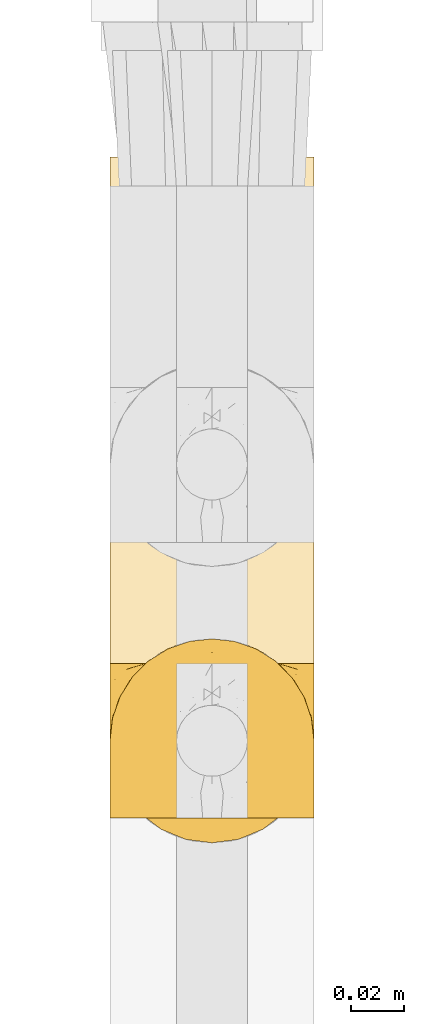
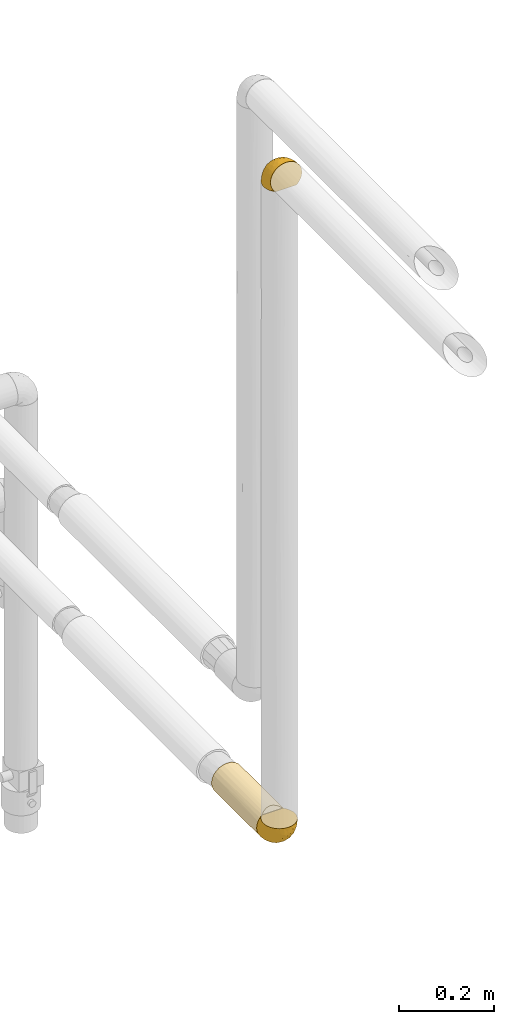
# One storey, part 60 of 827: 3 coverings.
"""IFC2X3 building model written with IfcOpenShell, lengths in millimetres."""

import ifcopenshell
import ifcopenshell.guid

model = None  # the IFC model being written
_history = None  # IfcOwnerHistory: only IFC2X3 demands one
_inside = {}  # id of a spatial element -> (the spatial element, [elements in it])
_under = {}  # id of a project, library or spatial element -> (it, [spatial elements below it])
_declared = {}  # id of a project -> (the project, [libraries it declares])
_typed = {}  # id of a type object -> (the type object, [elements of that type])
_made_of = {}  # id of a material, layer set ... -> (it, [elements and type objects made of it])


def new_model(schema):
    """Start an empty IFC model of exactly this schema.

    Asked for "IFC4X3", IfcOpenShell would pick the latest addendum, in which some entities
    have other attributes; the version numbers below select the first issue.
    IFC2X3 requires an IfcOwnerHistory on every rooted entity: one is made here for all.
    """
    global model, _history
    if schema == "IFC4X3":
        model = ifcopenshell.file(schema_version=(4, 3, 0, 0))
    else:
        model = ifcopenshell.file(schema=schema)
    _inside.clear()
    _under.clear()
    _declared.clear()
    _typed.clear()
    _made_of.clear()
    _history = None
    if model.schema == "IFC2X3":
        org = make("IfcOrganization", Name="unknown")
        user = make(
            "IfcPersonAndOrganization",
            ThePerson=make("IfcPerson", FamilyName="unknown"),
            TheOrganization=org,
        )
        app = make(
            "IfcApplication",
            ApplicationDeveloper=org,
            Version="unknown",
            ApplicationFullName="unknown",
            ApplicationIdentifier="unknown",
        )
        _history = make(
            "IfcOwnerHistory",
            OwningUser=user,
            OwningApplication=app,
            ChangeAction="ADDED",
            CreationDate=0,
        )
    return model


def make(cls, **values):
    """One entity of the class cls with the attributes given. An attribute that is None is left unset."""
    return model.create_entity(
        cls, **{name: value for name, value in values.items() if value is not None}
    )


def entity(cls, *values):
    """Any entity or typed value of the class cls, its attributes in the order of the schema. None: left unset."""
    e = model.create_entity(cls)
    for i, value in enumerate(values):
        if value is not None:
            e[i] = value
    return e


def rooted(cls, **values):
    """An entity with a GlobalId (a new one), such as an element, a storey or a relation."""
    return make(cls, GlobalId=ifcopenshell.guid.new(), OwnerHistory=_history, **values)


def si_unit(unit_type, name, prefix=None):
    """IfcSIUnit, for example si_unit("LENGTHUNIT", "METRE", prefix="MILLI")."""
    return make("IfcSIUnit", UnitType=unit_type, Prefix=prefix, Name=name)


def converted_unit(unit_type, name, factor, base, dimensions=None, offset=None):
    """IfcConversionBasedUnit, such as the inch: factor (a typed value) times the base unit."""
    return make(
        "IfcConversionBasedUnit"
        if offset is None
        else "IfcConversionBasedUnitWithOffset",
        ConversionOffset=offset,
        Dimensions=None
        if dimensions is None
        else entity("IfcDimensionalExponents", *dimensions),
        UnitType=unit_type,
        Name=name,
        ConversionFactor=make(
            "IfcMeasureWithUnit", ValueComponent=factor, UnitComponent=base
        ),
    )


def derived_unit(unit_type, elements):
    """IfcDerivedUnit: a product of units, each with its exponent."""
    return make(
        "IfcDerivedUnit",
        Elements=[
            make("IfcDerivedUnitElement", Unit=unit, Exponent=power)
            for unit, power in elements
        ],
        UnitType=unit_type,
    )


def assignment(units):
    """IfcUnitAssignment: the units of a project."""
    return None if units is None else make("IfcUnitAssignment", Units=units)


def point(xyz):
    """IfcCartesianPoint."""
    return None if xyz is None else make("IfcCartesianPoint", Coordinates=xyz)


def direction(xyz):
    """IfcDirection."""
    return None if xyz is None else make("IfcDirection", DirectionRatios=xyz)


def frame(location, z_axis=None, x_axis=None):
    """IfcAxis2Placement3D, a coordinate frame: its origin and axes. An axis left out is left unset."""
    return make(
        "IfcAxis2Placement3D",
        Location=point(location),
        Axis=direction(z_axis),
        RefDirection=direction(x_axis),
    )


def origin():
    """The frame at (0, 0, 0) with its axes left unset."""
    return frame((0.0, 0.0, 0.0))


def place(relative_to, where):
    """IfcLocalPlacement: puts the frame where relative to a parent placement (None: the world)."""
    return make(
        "IfcLocalPlacement", PlacementRelTo=relative_to, RelativePlacement=where
    )


def context(
    kind, dimensions, precision=None, world=None, true_north=None, identifier=None
):
    """IfcGeometricRepresentationContext, for example the 3D "Model" context."""
    return make(
        "IfcGeometricRepresentationContext",
        ContextIdentifier=identifier,
        ContextType=kind,
        CoordinateSpaceDimension=dimensions,
        Precision=precision,
        WorldCoordinateSystem=world,
        TrueNorth=true_north,
    )


def subcontext(parent, identifier, kind, view, scale=None):
    """IfcGeometricRepresentationSubContext, for example "Body" below "Model"."""
    return make(
        "IfcGeometricRepresentationSubContext",
        ContextIdentifier=identifier,
        ContextType=kind,
        ParentContext=parent,
        TargetScale=scale,
        TargetView=view,
    )


def project(units=None, contexts=None):
    """IfcProject with its units and contexts."""
    return rooted(
        "IfcProject",
        Name="project",
        RepresentationContexts=contexts,
        UnitsInContext=assignment(units),
    )


def spatial(cls, under=None, at=None, **own):
    """A site, building, storey or space (cls), placed at a placement, below another one or the project."""
    s = rooted(cls, ObjectPlacement=at, **own)
    if under is not None:
        _under.setdefault(under.id(), (under, []))[1].append(s)
    return s


def faces_of(points, faces, orient=None, outer=None):
    """IfcFace entities. A face is a list of loops; a loop is a list of indices into points, from 0.

    orient and outer hold one flag for each loop. By default every Orientation is true, the
    first loop of a face is its IfcFaceOuterBound and the others are IfcFaceBound.
    """
    made = []
    for i, loops in enumerate(faces):
        bounds = []
        for j, loop in enumerate(loops):
            is_outer = j == 0 if outer is None else outer[i][j]
            bounds.append(
                make(
                    "IfcFaceOuterBound" if is_outer else "IfcFaceBound",
                    Bound=make("IfcPolyLoop", Polygon=[points[k] for k in loop]),
                    Orientation=True if orient is None else orient[i][j],
                )
            )
        made.append(make("IfcFace", Bounds=bounds))
    return made


def faceted_brep(points, faces, orient=None, outer=None, voids=None):
    """IfcFacetedBrep: a solid bounded by flat faces; with voids (closed shells), ...WithVoids."""
    shared = [point(p) for p in points]
    hull = make("IfcClosedShell", CfsFaces=faces_of(shared, faces, orient, outer))
    if voids is None:
        return make("IfcFacetedBrep", Outer=hull)
    return make(
        "IfcFacetedBrepWithVoids",
        Outer=hull,
        Voids=[
            make(cls, CfsFaces=faces_of(shared, fs, o, b)) for cls, fs, o, b in voids
        ],
    )


def shape(context_of_items, identifier, shape_type, items):
    """IfcShapeRepresentation: the items that make up one representation, for example the "Body"."""
    return make(
        "IfcShapeRepresentation",
        ContextOfItems=context_of_items,
        RepresentationIdentifier=identifier,
        RepresentationType=shape_type,
        Items=items,
    )


def made_of(thing, what):
    """Note that an element or type object is made of a material, layer set ...; save() writes the relation."""
    if what is not None:
        _made_of.setdefault(what.id(), (what, []))[1].append(thing)
    return thing


def element(
    cls,
    number,
    at=None,
    inside=None,
    cuts=None,
    type_object=None,
    material=None,
    context=None,
    identifier="Body",
    shape_type=None,
    held_by="IfcProductDefinitionShape",
    body=None,
    shapes=None,
    **own,
):
    """One element of the class cls, such as IfcWall. Its Tag is "e" and its number.

    at: its placement. inside: the storey or other place that contains it. cuts: it is an
    opening in that element (IfcRelVoidsElement). A single representation is given by context,
    identifier, shape_type and body (its items); several are given by shapes. held_by: the class
    of the entity that holds the representations. save() writes the other relations.
    """
    e = rooted(cls, Tag="e%d" % number, ObjectPlacement=at, **own)
    if body is not None:
        shapes = [shape(context, identifier, shape_type, body)]
    if shapes is not None:
        e.Representation = make(held_by, Representations=shapes)
    if inside is not None:
        _inside.setdefault(inside.id(), (inside, []))[1].append(e)
    if cuts is not None:
        rooted(
            "IfcRelVoidsElement", RelatingBuildingElement=cuts, RelatedOpeningElement=e
        )
    if type_object is not None:
        _typed.setdefault(type_object.id(), (type_object, []))[1].append(e)
    return made_of(e, material)


def aggregate(whole, parts):
    """IfcRelAggregates: a whole, such as a stair, and the parts it consists of."""
    return rooted("IfcRelAggregates", RelatingObject=whole, RelatedObjects=parts)


def save(model, path):
    """Write the relations noted so far, then the file.

    IfcRelAggregates (storeys below a building ...), IfcRelContainedInSpatialStructure (elements
    in a storey), IfcRelDefinesByType, IfcRelAssociatesMaterial and IfcRelDeclares: one each for
    every whole, place, type object, material and project.
    """
    for whole, parts in _under.values():
        aggregate(whole, parts)
    for where, things in _inside.values():
        rooted(
            "IfcRelContainedInSpatialStructure",
            RelatedElements=things,
            RelatingStructure=where,
        )
    for kind, things in _typed.values():
        rooted("IfcRelDefinesByType", RelatedObjects=things, RelatingType=kind)
    for what, things in _made_of.values():
        rooted("IfcRelAssociatesMaterial", RelatedObjects=things, RelatingMaterial=what)
    for by, libraries in _declared.values():
        rooted("IfcRelDeclares", RelatingContext=by, RelatedDefinitions=libraries)
    model.write(path)


model = new_model("IFC2X3")

# Units and contexts
model_context = context("Model", 3, precision=0.01, world=origin(), true_north=direction((6.12303176911189e-17, 1.0)))
body_context = subcontext(model_context, "Body", "Model", "MODEL_VIEW")
ifc_project = project(units=[si_unit("LENGTHUNIT", "METRE", prefix="MILLI"), si_unit("AREAUNIT", "SQUARE_METRE"), si_unit("VOLUMEUNIT", "CUBIC_METRE"), converted_unit("PLANEANGLEUNIT", "DEGREE", entity("IfcRatioMeasure", 0.0174532925199433), si_unit("PLANEANGLEUNIT", "RADIAN"), dimensions=[0, 0, 0, 0, 0, 0, 0]), si_unit("MASSUNIT", "GRAM", prefix="KILO"), derived_unit("MASSDENSITYUNIT", [(si_unit("MASSUNIT", "GRAM", prefix="KILO"), 1), (si_unit("LENGTHUNIT", "METRE"), -3)]), derived_unit("MOMENTOFINERTIAUNIT", [(si_unit("LENGTHUNIT", "METRE"), 4)]), si_unit("TIMEUNIT", "SECOND"), si_unit("FREQUENCYUNIT", "HERTZ"), si_unit("THERMODYNAMICTEMPERATUREUNIT", "DEGREE_CELSIUS"), derived_unit("THERMALTRANSMITTANCEUNIT", [(si_unit("MASSUNIT", "GRAM", prefix="KILO"), 1), (si_unit("THERMODYNAMICTEMPERATUREUNIT", "KELVIN"), -1), (si_unit("TIMEUNIT", "SECOND"), -3)]), derived_unit("VOLUMETRICFLOWRATEUNIT", [(si_unit("LENGTHUNIT", "METRE"), 3), (si_unit("TIMEUNIT", "SECOND"), -1)]), derived_unit("MASSFLOWRATEUNIT", [(si_unit("MASSUNIT", "GRAM", prefix="KILO"), 1), (si_unit("TIMEUNIT", "SECOND"), -1)]), derived_unit("ROTATIONALFREQUENCYUNIT", [(si_unit("TIMEUNIT", "SECOND"), -1)]), si_unit("ELECTRICCURRENTUNIT", "AMPERE"), si_unit("ELECTRICVOLTAGEUNIT", "VOLT"), si_unit("POWERUNIT", "WATT"), si_unit("FORCEUNIT", "NEWTON", prefix="KILO"), si_unit("ILLUMINANCEUNIT", "LUX"), si_unit("LUMINOUSFLUXUNIT", "LUMEN"), si_unit("LUMINOUSINTENSITYUNIT", "CANDELA"), derived_unit("USERDEFINED", [(si_unit("MASSUNIT", "GRAM", prefix="KILO"), -1), (si_unit("LENGTHUNIT", "METRE"), -2), (si_unit("TIMEUNIT", "SECOND"), 3), (si_unit("LUMINOUSFLUXUNIT", "LUMEN"), 1)]), derived_unit("LINEARVELOCITYUNIT", [(si_unit("LENGTHUNIT", "METRE"), 1), (si_unit("TIMEUNIT", "SECOND"), -1)]), si_unit("PRESSUREUNIT", "PASCAL"), derived_unit("USERDEFINED", [(si_unit("LENGTHUNIT", "METRE"), -2), (si_unit("MASSUNIT", "GRAM", prefix="KILO"), 1), (si_unit("TIMEUNIT", "SECOND"), -2)]), derived_unit("LINEARFORCEUNIT", [(si_unit("MASSUNIT", "GRAM", prefix="KILO"), 1), (si_unit("LENGTHUNIT", "METRE"), 1), (si_unit("TIMEUNIT", "SECOND"), -2), (si_unit("LENGTHUNIT", "METRE"), -1)]), derived_unit("PLANARFORCEUNIT", [(si_unit("MASSUNIT", "GRAM", prefix="KILO"), 1), (si_unit("LENGTHUNIT", "METRE"), 1), (si_unit("TIMEUNIT", "SECOND"), -2), (si_unit("LENGTHUNIT", "METRE"), -2)])], contexts=[model_context])

# Site, building, storey
site_placement = place(None, origin())
site = spatial("IfcSite", under=ifc_project, at=site_placement, CompositionType="ELEMENT")
building_placement = place(site_placement, origin())
building = spatial("IfcBuilding", under=site, at=building_placement, CompositionType="ELEMENT")
storey_placement = place(building_placement, frame((0.0, 0.0, 28200.0)))
storey = spatial("IfcBuildingStorey", under=building, at=storey_placement, Name="08", CompositionType="ELEMENT", Elevation=28200.0)

# Coverings
covering_1_placement = place(storey_placement, frame((13238.75, 11029.69, 2669.3)))
element("IfcCovering", 1, at=covering_1_placement, inside=storey, Name=":ADSK_", ObjectType=":ADSK_", PredefinedType="INSULATION", context=body_context, shape_type="Brep", body=[
    faceted_brep([(5.41, 47.38, 1.6), (9.99, 54.67, 1.6), (16.08, 60.76, 1.6), (23.37, 65.34, 1.6), (31.49, 68.18, 1.6), (40.05, 69.15, 1.6), (48.61, 68.18, 1.6), (56.73, 65.33, 1.6), (64.02, 60.75, 1.6), (70.11, 54.66, 1.6), (74.69, 47.37, 1.6), (77.53, 39.25, 1.6), (78.5, 30.7, 1.6), (77.63, 22.59, 1.6), (75.08, 14.86, 1.6), (70.97, 7.84, 1.6), (65.47, 1.85, 1.6), (63.27, 1.85, 1.6), (61.53, 1.85, 1.6), (59.57, 1.85, 1.6), (57.6, 1.85, 1.6), (55.63, 1.85, 1.6), (53.67, 1.85, 1.6), (51.7, 1.85, 1.6), (49.73, 1.85, 1.6), (47.54, 1.85, 1.6), (45.34, 1.85, 1.6), (43.15, 1.85, 1.6), (40.96, 1.85, 1.6), (38.76, 1.85, 1.6), (36.57, 1.85, 1.6), (34.37, 1.85, 1.6), (32.18, 1.85, 1.6), (29.98, 1.85, 1.6), (27.79, 1.85, 1.6), (25.6, 1.85, 1.6), (23.4, 1.85, 1.6), (21.21, 1.85, 1.6), (19.01, 1.85, 1.6), (16.82, 1.85, 1.6), (14.62, 1.85, 1.6), (9.12, 7.85, 1.6), (5.0, 14.88, 1.6), (2.46, 22.61, 1.6), (1.6, 30.7, 1.6), (2.56, 39.26, 1.6), (65.47, 1.6, 1.85), (70.97, 1.6, 7.85), (75.09, 1.6, 14.87), (77.63, 1.6, 22.6), (78.5, 1.6, 30.7), (77.19, 1.6, 40.65), (73.34, 1.6, 49.92), (67.23, 1.6, 57.88), (59.27, 1.6, 63.99), (50.0, 1.6, 67.84), (40.05, 1.6, 69.15), (30.09, 1.6, 67.84), (20.82, 1.6, 63.99), (12.86, 1.6, 57.88), (6.75, 1.6, 49.92), (2.91, 1.6, 40.65), (1.6, 1.6, 30.7), (2.46, 1.6, 22.6), (5.0, 1.6, 14.87), (9.12, 1.6, 7.85), (14.62, 1.6, 1.85), (16.82, 1.6, 1.85), (17.8, 1.6, 1.85), (19.39, 1.6, 1.85), (20.98, 1.6, 1.85), (22.57, 1.6, 1.85), (24.16, 1.6, 1.85), (25.75, 1.6, 1.85), (27.33, 1.6, 1.85), (28.92, 1.6, 1.85), (30.51, 1.6, 1.85), (32.1, 1.6, 1.85), (33.69, 1.6, 1.85), (35.28, 1.6, 1.85), (36.87, 1.6, 1.85), (38.46, 1.6, 1.85), (40.05, 1.6, 1.85), (41.63, 1.6, 1.85), (43.22, 1.6, 1.85), (44.81, 1.6, 1.85), (46.4, 1.6, 1.85), (47.99, 1.6, 1.85), (49.58, 1.6, 1.85), (51.17, 1.6, 1.85), (52.76, 1.6, 1.85), (54.72, 1.6, 1.85), (56.69, 1.6, 1.85), (58.88, 1.6, 1.85), (61.08, 1.6, 1.85), (63.27, 1.6, 1.85), (37.77, 1.78, 1.77), (36.07, 1.77, 1.78), (32.96, 1.78, 1.77), (31.36, 1.77, 1.77), (56.52, 1.79, 1.76), (54.96, 1.78, 1.77), (18.75, 1.76, 1.79), (58.07, 1.77, 1.78), (50.37, 1.77, 1.78), (23.36, 1.76, 1.78), (24.95, 1.77, 1.78), (42.43, 1.77, 1.78), (15.97, 1.8, 1.74), (51.96, 1.76, 1.78), (53.47, 1.77, 1.78), (48.63, 1.78, 1.77), (63.93, 1.77, 1.78), (40.93, 1.77, 1.78), (29.72, 1.76, 1.78), (62.4, 1.77, 1.77), (60.92, 1.78, 1.77), (17.31, 1.77, 1.77), (21.74, 1.77, 1.78), (34.56, 1.77, 1.78), (20.18, 1.78, 1.77), (14.62, 1.77, 1.77), (14.62, 1.8, 1.72), (14.62, 1.82, 1.66), (65.47, 1.77, 1.77), (65.47, 1.72, 1.8), (65.47, 1.66, 1.82), (59.5, 1.76, 1.79), (47.1, 1.77, 1.78), (45.61, 1.76, 1.79), (28.18, 1.77, 1.78), (14.62, 1.66, 1.82), (14.62, 1.72, 1.8), (26.61, 1.78, 1.76), (65.47, 1.82, 1.66), (65.47, 1.8, 1.72), (39.32, 1.77, 1.78), (44.12, 1.78, 1.77), (72.26, 3.72, 9.41), (76.57, 7.41, 17.65), (71.77, 6.13, 7.41), (78.5, 21.47, 21.47), (77.9, 19.34, 15.21), (78.5, 26.8, 16.15), (78.5, 8.87, 28.75), (75.52, 9.2, 13.67), (76.13, 12.79, 12.79), (77.81, 14.62, 19.18), (78.5, 7.34, 29.16), (72.4, 5.33, 9.04), (76.56, 17.64, 7.41), (71.77, 7.7, 5.74), (72.25, 9.41, 3.72), (78.5, 28.75, 8.87), (78.5, 16.15, 26.8), (75.75, 14.14, 9.53), (78.5, 29.16, 7.34), (50.46, 57.02, 37.63), (52.75, 64.92, 17.92), (40.05, 64.0, 27.45), (77.7, 11.92, 37.01), (77.66, 19.16, 34.22), (71.02, 28.65, 45.87), (63.45, 24.62, 56.57), (70.55, 15.19, 52.31), (75.57, 18.36, 42.07), (75.57, 9.2, 44.74), (72.61, 46.98, 21.49), (72.61, 50.24, 11.02), (67.24, 56.1, 15.64), (77.74, 28.97, 26.02), (57.43, 54.46, 36.59), (47.19, 21.34, 65.49), (54.76, 18.4, 63.99), (40.05, 66.44, 15.2), (63.45, 12.07, 60.27), (60.1, 45.49, 45.25), (63.72, 50.57, 35.21), (76.83, 36.04, 22.52), (76.34, 42.07, 12.03), (60.51, 62.12, 13.32), (72.59, 37.37, 35.9), (76.05, 29.39, 33.87), (66.15, 53.59, 25.73), (60.51, 58.06, 26.34), (51.88, 49.27, 46.78), (55.34, 29.63, 59.54), (48.67, 33.21, 60.18), (53.89, 40.1, 53.93), (46.73, 44.08, 53.36), (40.05, 49.36, 49.36), (40.05, 56.68, 38.4), (40.05, 15.2, 66.44), (63.95, 35.57, 50.09), (67.24, 41.7, 41.08), (69.62, 46.4, 31.14), (73.6, 41.41, 28.19), (40.05, 27.45, 64.0), (40.05, 38.4, 56.68), (4.52, 12.99, 43.9), (32.72, 21.33, 65.46), (27.18, 42.89, 52.22), (29.63, 57.04, 37.61), (12.86, 56.11, 15.64), (19.59, 62.13, 13.31), (9.54, 21.89, 50.02), (16.64, 16.62, 59.28), (17.48, 32.9, 53.05), (7.49, 46.99, 21.48), (7.49, 50.25, 11.01), (3.75, 42.08, 12.03), (20.75, 49.91, 41.02), (2.33, 15.6, 35.39), (1.6, 16.15, 26.8), (1.6, 8.87, 28.75), (1.6, 29.16, 7.34), (26.94, 13.16, 65.81), (9.54, 10.83, 53.28), (31.21, 33.8, 59.8), (25.33, 25.02, 61.82), (27.35, 64.92, 17.91), (8.17, 32.83, 41.4), (4.3, 20.56, 40.48), (19.59, 58.07, 26.34), (2.23, 21.46, 31.68), (2.45, 28.1, 27.68), (1.6, 26.8, 16.15), (1.6, 21.47, 21.47), (12.86, 51.29, 28.05), (3.27, 36.04, 22.54), (1.6, 28.75, 8.87), (2.29, 8.45, 37.3), (12.86, 41.73, 41.07), (6.89, 39.27, 32.24), (12.43, 33.56, 47.4), (4.1, 27.29, 35.77), (3.53, 7.41, 17.65), (6.88, 3.51, 11.06), (8.16, 4.68, 8.55), (9.02, 5.52, 6.63), (5.0, 8.75, 12.77), (3.96, 12.79, 12.79), (3.52, 17.65, 7.41), (2.4, 13.9, 18.97), (7.83, 9.42, 3.72), (8.32, 7.68, 5.76), (2.19, 19.33, 15.21), (4.34, 14.13, 9.52)], [[[0, 1, 2, 3, 4, 5, 6, 7, 8, 9, 10, 11, 12, 13, 14, 15, 16, 17, 18, 19, 20, 21, 22, 23, 24, 25, 26, 27, 28, 29, 30, 31, 32, 33, 34, 35, 36, 37, 38, 39, 40, 41, 42, 43, 44, 45]], [[46, 47, 48, 49, 50, 51, 52, 53, 54, 55, 56, 57, 58, 59, 60, 61, 62, 63, 64, 65, 66, 67, 68, 69, 70, 71, 72, 73, 74, 75, 76, 77, 78, 79, 80, 81, 82, 83, 84, 85, 86, 87, 88, 89, 90, 91, 92, 93, 94, 95]], [[96, 97, 30]], [[98, 77, 99]], [[100, 101, 21]], [[69, 68, 102]], [[20, 19, 103]], [[24, 23, 104]], [[20, 103, 100]], [[72, 105, 106]], [[84, 83, 107]], [[89, 88, 104]], [[108, 67, 66]], [[109, 110, 90]], [[111, 25, 24]], [[112, 17, 16]], [[82, 113, 83]], [[109, 23, 22]], [[114, 76, 75]], [[105, 36, 106]], [[104, 111, 24]], [[18, 115, 116]], [[97, 96, 80]], [[67, 108, 117]], [[105, 71, 118]], [[31, 97, 119]], [[102, 120, 69]], [[108, 121, 122, 123, 40]], [[112, 95, 115]], [[17, 115, 18]], [[94, 116, 115]], [[117, 68, 67]], [[38, 117, 39]], [[112, 124, 125, 126, 46]], [[17, 112, 115]], [[70, 120, 118]], [[39, 117, 108]], [[120, 38, 37]], [[120, 37, 118]], [[120, 70, 69]], [[116, 94, 127]], [[128, 86, 129]], [[117, 38, 102]], [[74, 130, 75]], [[99, 33, 32]], [[115, 95, 94]], [[39, 108, 40]], [[108, 66, 131, 132, 121]], [[105, 72, 71]], [[118, 37, 36]], [[71, 70, 118]], [[35, 106, 36]], [[36, 105, 118]], [[35, 133, 106]], [[74, 73, 133]], [[106, 133, 73]], [[99, 114, 33]], [[133, 35, 34]], [[73, 72, 106]], [[95, 112, 46]], [[112, 16, 134, 135, 124]], [[130, 114, 75]], [[99, 76, 114]], [[114, 130, 33]], [[34, 33, 130]], [[78, 77, 98]], [[98, 119, 78]], [[130, 133, 34]], [[133, 130, 74]], [[79, 97, 80]], [[98, 99, 32]], [[98, 32, 31]], [[77, 76, 99]], [[97, 79, 119]], [[136, 96, 29]], [[30, 97, 31]], [[136, 29, 28]], [[81, 80, 96]], [[29, 96, 30]], [[31, 119, 98]], [[119, 79, 78]], [[96, 136, 81]], [[82, 81, 136]], [[113, 107, 83]], [[84, 107, 137]], [[107, 27, 137]], [[113, 28, 107]], [[27, 107, 28]], [[85, 84, 137]], [[137, 27, 26]], [[113, 136, 28]], [[136, 113, 82]], [[109, 89, 104]], [[86, 85, 129]], [[89, 109, 90]], [[111, 87, 128]], [[26, 129, 137]], [[88, 111, 104]], [[25, 111, 128]], [[22, 110, 109]], [[23, 109, 104]], [[110, 91, 90]], [[100, 92, 101]], [[110, 22, 101]], [[91, 110, 101]], [[116, 19, 18]], [[111, 88, 87]], [[127, 103, 19]], [[25, 128, 26]], [[86, 128, 87]], [[128, 129, 26]], [[137, 129, 85]], [[120, 102, 38]], [[117, 102, 68]], [[91, 101, 92]], [[21, 101, 22]], [[93, 92, 103]], [[100, 21, 20]], [[100, 103, 92]], [[127, 93, 103]], [[93, 127, 94]], [[116, 127, 19]], [[126, 138, 47]], [[48, 138, 139]], [[140, 125, 124]], [[141, 142, 143]], [[144, 49, 139]], [[145, 140, 146]], [[48, 139, 49]], [[139, 145, 147]], [[49, 144, 148, 50]], [[126, 125, 149]], [[14, 13, 150]], [[151, 146, 140]], [[149, 140, 145]], [[152, 151, 135]], [[152, 14, 150]], [[16, 15, 134]], [[13, 153, 150]], [[124, 151, 140]], [[141, 147, 142]], [[14, 152, 15]], [[15, 152, 134]], [[47, 46, 126]], [[139, 154, 144]], [[138, 48, 47]], [[125, 140, 149]], [[135, 134, 152]], [[146, 155, 142]], [[145, 146, 147]], [[149, 139, 138]], [[147, 141, 154]], [[147, 146, 142]], [[139, 147, 154]], [[139, 149, 145]], [[149, 138, 126]], [[155, 146, 151]], [[150, 143, 142]], [[152, 155, 151]], [[150, 142, 155]], [[13, 12, 156, 153]], [[153, 143, 150]], [[152, 150, 155]], [[151, 124, 135]], [[157, 158, 159]], [[160, 154, 161]], [[162, 163, 164]], [[165, 166, 160]], [[167, 168, 169]], [[141, 170, 161]], [[156, 12, 11]], [[158, 157, 171]], [[172, 55, 173]], [[158, 6, 174]], [[175, 54, 53]], [[52, 166, 164]], [[52, 164, 53]], [[54, 175, 173]], [[166, 52, 51]], [[176, 177, 171]], [[178, 143, 179]], [[156, 11, 179]], [[8, 7, 180]], [[169, 9, 8]], [[179, 143, 153, 156]], [[179, 11, 10]], [[168, 179, 10]], [[181, 162, 182]], [[179, 167, 178]], [[183, 184, 177]], [[183, 169, 184]], [[176, 171, 185]], [[172, 186, 187]], [[158, 7, 6]], [[159, 158, 174]], [[184, 180, 158]], [[54, 173, 55]], [[180, 169, 8]], [[188, 189, 187]], [[9, 168, 10]], [[186, 188, 187]], [[190, 157, 159, 191]], [[55, 172, 192]], [[176, 193, 194]], [[161, 170, 182]], [[162, 164, 165]], [[175, 164, 163]], [[51, 50, 148]], [[167, 195, 196]], [[178, 182, 170]], [[6, 5, 174]], [[158, 180, 7]], [[169, 180, 184]], [[169, 168, 9]], [[179, 168, 167]], [[182, 162, 165]], [[162, 194, 193]], [[161, 165, 160]], [[195, 181, 196]], [[192, 172, 197]], [[192, 56, 55]], [[189, 190, 198]], [[198, 197, 187]], [[172, 187, 197]], [[185, 189, 188]], [[198, 187, 189]], [[186, 172, 173]], [[173, 163, 186]], [[193, 186, 163]], [[176, 185, 188]], [[185, 157, 190]], [[188, 186, 193]], [[177, 176, 194]], [[188, 193, 176]], [[162, 193, 163]], [[195, 177, 194]], [[171, 177, 184]], [[181, 195, 194]], [[183, 167, 169]], [[162, 181, 194]], [[196, 182, 178]], [[158, 171, 184]], [[171, 157, 185]], [[177, 195, 183]], [[167, 183, 195]], [[182, 196, 181]], [[178, 170, 143]], [[178, 167, 196]], [[164, 175, 53]], [[173, 175, 163]], [[160, 51, 148]], [[164, 166, 165]], [[51, 160, 166]], [[160, 148, 144, 154]], [[141, 161, 154]], [[182, 165, 161]], [[190, 189, 185]], [[143, 170, 141]], [[60, 199, 61]], [[197, 200, 192]], [[201, 190, 202]], [[200, 57, 192]], [[203, 204, 2]], [[205, 206, 207]], [[208, 209, 210]], [[211, 207, 201]], [[212, 213, 214]], [[45, 215, 210]], [[216, 206, 58]], [[45, 44, 215]], [[59, 217, 60]], [[60, 217, 199]], [[0, 45, 210]], [[218, 201, 219]], [[202, 159, 220]], [[205, 221, 222]], [[223, 204, 203]], [[1, 203, 2]], [[57, 200, 216]], [[220, 3, 204]], [[220, 174, 4]], [[1, 0, 209]], [[212, 224, 213]], [[225, 226, 227]], [[228, 223, 203]], [[208, 210, 229]], [[210, 226, 229]], [[3, 220, 4]], [[58, 206, 59]], [[209, 203, 1]], [[202, 220, 223]], [[228, 203, 208]], [[202, 211, 201]], [[3, 2, 204]], [[202, 190, 191, 159]], [[210, 215, 230, 226]], [[199, 212, 231]], [[232, 233, 221]], [[233, 208, 229]], [[207, 206, 219]], [[217, 206, 205]], [[227, 224, 225]], [[233, 232, 228]], [[201, 207, 219]], [[234, 232, 221]], [[218, 219, 200]], [[202, 223, 211]], [[174, 220, 159]], [[174, 5, 4]], [[61, 231, 62]], [[220, 204, 223]], [[210, 209, 0]], [[203, 209, 208]], [[225, 233, 229]], [[224, 227, 213]], [[221, 233, 235]], [[57, 56, 192]], [[198, 218, 197]], [[200, 219, 216]], [[201, 198, 190]], [[197, 218, 200]], [[198, 201, 218]], [[206, 216, 219]], [[58, 57, 216]], [[231, 212, 214]], [[222, 212, 199]], [[228, 211, 223]], [[207, 211, 232]], [[62, 231, 214]], [[199, 231, 61]], [[233, 228, 208]], [[211, 228, 232]], [[222, 221, 235]], [[234, 205, 207]], [[206, 217, 59]], [[199, 217, 205]], [[205, 222, 199]], [[224, 222, 235]], [[222, 224, 212]], [[224, 235, 225]], [[233, 225, 235]], [[226, 225, 229]], [[205, 234, 221]], [[207, 232, 234]], [[63, 214, 236]], [[214, 213, 236]], [[214, 63, 62]], [[237, 236, 238]], [[238, 132, 131]], [[236, 237, 64]], [[239, 240, 241]], [[63, 236, 64]], [[131, 66, 65]], [[237, 131, 65]], [[242, 230, 43]], [[237, 65, 64]], [[239, 121, 132]], [[42, 242, 43]], [[241, 240, 243]], [[41, 123, 244]], [[43, 230, 215, 44]], [[244, 122, 245]], [[227, 246, 243]], [[241, 247, 245]], [[121, 239, 245]], [[41, 40, 123]], [[132, 238, 239]], [[244, 42, 41]], [[131, 237, 238]], [[240, 239, 238]], [[245, 239, 241]], [[247, 241, 246]], [[247, 244, 245]], [[238, 236, 240]], [[243, 236, 213]], [[236, 243, 240]], [[227, 226, 246]], [[243, 213, 227]], [[242, 246, 226]], [[243, 246, 241]], [[246, 242, 247]], [[244, 247, 242]], [[242, 226, 230]], [[42, 244, 242]], [[122, 244, 123]], [[122, 121, 245]]]),
])
covering_2_placement = place(storey_placement, frame((13238.8, 11087.89, 960.01)))
element("IfcCovering", 2, at=covering_2_placement, inside=storey, Name=":ADSK_", ObjectType=":ADSK_", PredefinedType="INSULATION", context=body_context, shape_type="Brep", body=[
    faceted_brep([(20.8, 1.6, 6.74), (30.06, 1.6, 2.9), (40.0, 1.6, 1.6), (49.93, 1.6, 2.9), (59.2, 1.6, 6.74), (67.15, 1.6, 12.84), (73.25, 1.6, 20.8), (77.09, 1.6, 30.06), (78.4, 1.6, 40.0), (77.51, 1.6, 48.2), (74.9, 1.6, 56.01), (70.68, 1.6, 63.08), (65.05, 1.6, 69.1), (14.94, 1.6, 69.1), (9.31, 1.6, 63.08), (5.09, 1.6, 56.01), (2.48, 1.6, 48.2), (1.6, 1.6, 40.0), (2.9, 1.6, 30.06), (6.74, 1.6, 20.8), (12.84, 1.6, 12.84), (20.8, 192.5, 6.74), (12.84, 192.5, 12.84), (6.74, 192.5, 20.8), (2.9, 192.5, 30.06), (1.6, 192.5, 40.0), (2.9, 192.5, 49.93), (6.74, 192.5, 59.2), (12.84, 192.5, 67.15), (20.8, 192.5, 73.25), (30.06, 192.5, 77.09), (40.0, 192.5, 78.4), (49.93, 192.5, 77.09), (59.2, 192.5, 73.25), (67.15, 192.5, 67.15), (73.25, 192.5, 59.2), (77.09, 192.5, 49.93), (78.4, 192.5, 40.0), (77.09, 192.5, 30.06), (73.25, 192.5, 20.8), (67.15, 192.5, 12.84), (59.2, 192.5, 6.74), (49.93, 192.5, 2.9), (40.0, 192.5, 1.6), (30.06, 192.5, 2.9), (53.36, 8.5, 76.0), (46.78, 10.29, 77.79), (40.0, 10.9, 78.4), (59.51, 5.57, 73.07), (33.21, 10.29, 77.79), (26.63, 8.5, 76.0), (20.48, 5.57, 73.07)], [[[0, 1, 2, 3, 4, 5, 6, 7, 8, 9, 10, 11, 12, 13, 14, 15, 16, 17, 18, 19, 20]], [[21, 22, 23, 24, 25, 26, 27, 28, 29, 30, 31, 32, 33, 34, 35, 36, 37, 38, 39, 40, 41, 42, 43, 44]], [[24, 23, 19, 18]], [[25, 24, 18, 17]], [[23, 22, 20, 19]], [[1, 0, 21, 44]], [[2, 1, 44, 43]], [[22, 21, 0, 20]], [[3, 2, 43, 42]], [[4, 3, 42, 41]], [[41, 40, 5, 4]], [[7, 6, 39, 38]], [[8, 7, 38, 37]], [[40, 39, 6, 5]], [[9, 37, 36]], [[10, 36, 35]], [[11, 35, 34]], [[8, 37, 9]], [[9, 36, 10]], [[35, 11, 10]], [[34, 12, 11]], [[45, 33, 32]], [[32, 31, 46]], [[47, 46, 31]], [[48, 12, 33]], [[46, 45, 32]], [[48, 33, 45]], [[33, 12, 34]], [[49, 47, 31]], [[49, 31, 30]], [[50, 30, 29]], [[50, 49, 30]], [[13, 51, 29]], [[50, 29, 51]], [[29, 28, 13]], [[14, 28, 27]], [[15, 27, 26]], [[16, 26, 25]], [[14, 27, 15]], [[15, 26, 16]], [[25, 17, 16]], [[28, 14, 13]], [[48, 45, 46, 47, 49, 50, 51, 13, 12]]]),
])
covering_3_placement = place(storey_placement, frame((13238.75, 11020.34, 959.96)))
element("IfcCovering", 3, at=covering_3_placement, inside=storey, Name=":ADSK_", ObjectType=":ADSK_", PredefinedType="INSULATION", context=body_context, shape_type="Brep", body=[
    faceted_brep([(74.68, 69.15, 23.36), (70.1, 69.15, 16.07), (64.01, 69.15, 9.98), (56.72, 69.15, 5.4), (48.6, 69.15, 2.56), (40.05, 69.15, 1.6), (31.49, 69.15, 2.56), (23.36, 69.15, 5.41), (16.07, 69.15, 9.99), (9.98, 69.15, 16.08), (5.4, 69.15, 23.37), (2.56, 69.15, 31.49), (1.6, 69.15, 40.05), (2.46, 69.15, 48.15), (5.01, 69.15, 55.88), (9.13, 69.15, 62.9), (14.62, 69.15, 68.89), (16.82, 69.15, 68.89), (18.56, 69.15, 68.89), (20.52, 69.15, 68.89), (22.49, 69.15, 68.89), (24.46, 69.15, 68.89), (26.42, 69.15, 68.89), (28.39, 69.15, 68.89), (30.36, 69.15, 68.89), (32.55, 69.15, 68.89), (34.75, 69.15, 68.89), (36.94, 69.15, 68.89), (39.13, 69.15, 68.89), (41.33, 69.15, 68.89), (43.52, 69.15, 68.89), (45.72, 69.15, 68.89), (47.91, 69.15, 68.89), (50.11, 69.15, 68.89), (52.3, 69.15, 68.89), (54.49, 69.15, 68.89), (56.69, 69.15, 68.89), (58.88, 69.15, 68.89), (61.08, 69.15, 68.89), (63.27, 69.15, 68.89), (65.47, 69.15, 68.89), (70.97, 69.15, 62.89), (75.09, 69.15, 55.86), (77.64, 69.15, 48.13), (78.5, 69.15, 40.05), (77.53, 69.15, 31.49), (14.62, 68.89, 69.15), (9.12, 62.89, 69.15), (5.0, 55.87, 69.15), (2.46, 48.14, 69.15), (1.6, 40.05, 69.15), (2.91, 30.09, 69.15), (6.75, 20.82, 69.15), (12.86, 12.86, 69.15), (20.82, 6.75, 69.15), (30.09, 2.91, 69.15), (40.05, 1.6, 69.15), (50.0, 2.91, 69.15), (59.27, 6.75, 69.15), (67.23, 12.86, 69.15), (73.34, 20.82, 69.15), (77.19, 30.09, 69.15), (78.5, 40.05, 69.15), (77.63, 48.14, 69.15), (75.09, 55.87, 69.15), (70.97, 62.89, 69.15), (65.47, 68.89, 69.15), (63.27, 68.89, 69.15), (62.29, 68.89, 69.15), (60.7, 68.89, 69.15), (59.11, 68.89, 69.15), (57.52, 68.89, 69.15), (55.93, 68.89, 69.15), (54.34, 68.89, 69.15), (52.76, 68.89, 69.15), (51.17, 68.89, 69.15), (49.58, 68.89, 69.15), (47.99, 68.89, 69.15), (46.4, 68.89, 69.15), (44.81, 68.89, 69.15), (43.22, 68.89, 69.15), (41.63, 68.89, 69.15), (40.05, 68.89, 69.15), (38.46, 68.89, 69.15), (36.87, 68.89, 69.15), (35.28, 68.89, 69.15), (33.69, 68.89, 69.15), (32.1, 68.89, 69.15), (30.51, 68.89, 69.15), (28.92, 68.89, 69.15), (27.33, 68.89, 69.15), (25.37, 68.89, 69.15), (23.4, 68.89, 69.15), (21.21, 68.89, 69.15), (19.01, 68.89, 69.15), (16.82, 68.89, 69.15), (42.32, 68.97, 68.96), (44.02, 68.96, 68.97), (47.13, 68.97, 68.97), (48.74, 68.97, 68.97), (23.57, 68.98, 68.95), (25.13, 68.97, 68.96), (61.34, 68.96, 68.98), (22.02, 68.96, 68.97), (29.72, 68.96, 68.97), (56.73, 68.96, 68.98), (55.14, 68.96, 68.97), (37.66, 68.96, 68.97), (64.12, 69.0, 68.94), (28.13, 68.96, 68.98), (26.62, 68.96, 68.98), (31.46, 68.97, 68.96), (16.16, 68.96, 68.97), (39.16, 68.96, 68.98), (50.37, 68.96, 68.98), (17.69, 68.97, 68.97), (19.17, 68.97, 68.96), (62.78, 68.97, 68.97), (58.35, 68.96, 68.97), (45.53, 68.96, 68.98), (59.91, 68.97, 68.96), (65.47, 68.97, 68.97), (65.47, 69.02, 68.94), (65.47, 69.08, 68.92), (14.62, 68.97, 68.97), (14.62, 68.94, 69.02), (14.62, 68.92, 69.08), (20.59, 68.96, 68.98), (32.99, 68.96, 68.97), (34.48, 68.95, 68.98), (51.91, 68.96, 68.97), (65.47, 68.92, 69.08), (65.47, 68.94, 69.02), (53.48, 68.98, 68.96), (14.62, 69.08, 68.92), (14.62, 69.02, 68.94), (40.77, 68.96, 68.97), (35.97, 68.97, 68.96), (7.84, 61.33, 67.02), (3.53, 53.1, 63.33), (8.32, 63.33, 64.61), (1.6, 49.27, 49.27), (2.19, 55.53, 51.4), (1.6, 54.6, 43.94), (1.6, 41.99, 61.87), (4.57, 57.07, 61.54), (3.96, 57.95, 57.95), (2.28, 51.56, 56.12), (1.6, 41.58, 63.4), (7.69, 61.7, 65.41), (3.53, 63.33, 53.1), (8.32, 65.0, 63.04), (7.84, 67.02, 61.33), (1.6, 61.87, 41.99), (1.6, 43.94, 54.6), (4.34, 61.21, 56.6), (1.6, 63.4, 41.58), (29.63, 33.11, 13.72), (27.34, 52.82, 5.82), (40.05, 43.3, 6.74), (2.39, 33.73, 58.82), (2.43, 36.52, 51.58), (9.07, 24.87, 42.09), (16.64, 14.17, 46.12), (9.54, 18.43, 55.56), (4.52, 28.67, 52.38), (4.52, 26.0, 61.54), (7.49, 49.25, 23.76), (7.49, 59.72, 20.5), (12.85, 55.1, 14.64), (2.35, 44.72, 41.77), (22.66, 34.15, 16.28), (32.9, 5.25, 49.4), (25.33, 6.75, 52.34), (40.05, 55.54, 4.3), (16.64, 10.47, 58.67), (19.99, 25.49, 25.26), (16.37, 35.53, 20.17), (3.26, 48.22, 34.7), (3.75, 58.71, 28.67), (19.58, 57.42, 8.62), (7.5, 34.84, 33.37), (4.04, 36.87, 41.35), (13.94, 45.01, 17.15), (19.58, 44.4, 12.68), (28.21, 23.96, 21.47), (24.75, 11.2, 41.11), (31.42, 10.56, 37.53), (26.2, 16.81, 30.64), (33.36, 17.38, 26.66), (40.05, 21.38, 21.38), (40.05, 32.34, 14.06), (40.05, 4.3, 55.54), (16.14, 20.65, 35.17), (12.85, 29.66, 29.04), (10.47, 39.6, 24.34), (6.49, 42.55, 29.33), (40.05, 6.74, 43.3), (40.05, 14.06, 32.34), (75.57, 26.84, 57.75), (47.37, 5.28, 49.41), (52.91, 18.52, 27.85), (50.46, 33.13, 13.7), (67.23, 55.1, 14.63), (60.5, 57.43, 8.61), (70.55, 20.72, 48.85), (63.45, 11.46, 54.13), (62.61, 17.69, 37.84), (72.6, 49.26, 23.75), (72.6, 59.73, 20.49), (76.34, 58.71, 28.66), (59.34, 29.72, 20.83), (77.76, 35.35, 55.15), (78.5, 43.94, 54.6), (78.5, 41.99, 61.87), (78.5, 63.4, 41.58), (53.16, 4.93, 57.58), (70.55, 17.46, 59.91), (48.88, 10.94, 36.94), (54.76, 8.92, 45.72), (52.74, 52.83, 5.82), (71.93, 29.34, 37.91), (75.79, 30.26, 50.18), (60.5, 44.4, 12.67), (77.86, 39.06, 49.29), (77.64, 43.06, 42.64), (78.5, 54.6, 43.94), (78.5, 49.27, 49.27), (67.23, 42.69, 19.45), (76.82, 48.2, 34.7), (78.5, 61.87, 41.99), (77.8, 33.44, 62.29), (67.23, 29.67, 29.01), (73.2, 38.5, 31.47), (67.66, 23.35, 37.18), (75.99, 34.97, 43.45), (76.57, 53.1, 63.33), (73.21, 59.68, 67.23), (71.93, 62.19, 66.07), (71.07, 64.11, 65.22), (75.09, 57.97, 61.99), (76.13, 57.95, 57.95), (76.57, 63.33, 53.09), (77.69, 51.77, 56.84), (72.26, 67.02, 61.33), (71.77, 64.98, 63.06), (77.9, 55.53, 51.41), (75.75, 61.22, 56.61)], [[[0, 1, 2, 3, 4, 5, 6, 7, 8, 9, 10, 11, 12, 13, 14, 15, 16, 17, 18, 19, 20, 21, 22, 23, 24, 25, 26, 27, 28, 29, 30, 31, 32, 33, 34, 35, 36, 37, 38, 39, 40, 41, 42, 43, 44, 45]], [[46, 47, 48, 49, 50, 51, 52, 53, 54, 55, 56, 57, 58, 59, 60, 61, 62, 63, 64, 65, 66, 67, 68, 69, 70, 71, 72, 73, 74, 75, 76, 77, 78, 79, 80, 81, 82, 83, 84, 85, 86, 87, 88, 89, 90, 91, 92, 93, 94, 95]], [[96, 97, 30]], [[98, 77, 99]], [[100, 101, 21]], [[69, 68, 102]], [[20, 19, 103]], [[24, 23, 104]], [[20, 103, 100]], [[72, 105, 106]], [[84, 83, 107]], [[89, 88, 104]], [[108, 67, 66]], [[109, 110, 90]], [[111, 25, 24]], [[112, 17, 16]], [[82, 113, 83]], [[109, 23, 22]], [[114, 76, 75]], [[105, 36, 106]], [[104, 111, 24]], [[18, 115, 116]], [[97, 96, 80]], [[67, 108, 117]], [[105, 71, 118]], [[31, 97, 119]], [[102, 120, 69]], [[108, 121, 122, 123, 40]], [[112, 95, 115]], [[17, 115, 18]], [[94, 116, 115]], [[117, 68, 67]], [[38, 117, 39]], [[112, 124, 125, 126, 46]], [[17, 112, 115]], [[70, 120, 118]], [[39, 117, 108]], [[120, 38, 37]], [[120, 37, 118]], [[120, 70, 69]], [[116, 94, 127]], [[128, 86, 129]], [[117, 38, 102]], [[74, 130, 75]], [[99, 33, 32]], [[115, 95, 94]], [[39, 108, 40]], [[108, 66, 131, 132, 121]], [[105, 72, 71]], [[118, 37, 36]], [[71, 70, 118]], [[35, 106, 36]], [[36, 105, 118]], [[35, 133, 106]], [[74, 73, 133]], [[106, 133, 73]], [[99, 114, 33]], [[133, 35, 34]], [[73, 72, 106]], [[95, 112, 46]], [[112, 16, 134, 135, 124]], [[130, 114, 75]], [[99, 76, 114]], [[114, 130, 33]], [[34, 33, 130]], [[78, 77, 98]], [[98, 119, 78]], [[130, 133, 34]], [[133, 130, 74]], [[79, 97, 80]], [[98, 99, 32]], [[98, 32, 31]], [[77, 76, 99]], [[97, 79, 119]], [[136, 96, 29]], [[30, 97, 31]], [[136, 29, 28]], [[81, 80, 96]], [[29, 96, 30]], [[31, 119, 98]], [[119, 79, 78]], [[96, 136, 81]], [[82, 81, 136]], [[113, 107, 83]], [[84, 107, 137]], [[107, 27, 137]], [[113, 28, 107]], [[27, 107, 28]], [[85, 84, 137]], [[137, 27, 26]], [[113, 136, 28]], [[136, 113, 82]], [[109, 89, 104]], [[86, 85, 129]], [[89, 109, 90]], [[111, 87, 128]], [[26, 129, 137]], [[88, 111, 104]], [[25, 111, 128]], [[22, 110, 109]], [[23, 109, 104]], [[110, 91, 90]], [[100, 92, 101]], [[110, 22, 101]], [[91, 110, 101]], [[116, 19, 18]], [[111, 88, 87]], [[127, 103, 19]], [[25, 128, 26]], [[86, 128, 87]], [[128, 129, 26]], [[137, 129, 85]], [[120, 102, 38]], [[117, 102, 68]], [[91, 101, 92]], [[21, 101, 22]], [[93, 92, 103]], [[100, 21, 20]], [[100, 103, 92]], [[127, 93, 103]], [[93, 127, 94]], [[116, 127, 19]], [[126, 138, 47]], [[48, 138, 139]], [[140, 125, 124]], [[141, 142, 143]], [[144, 49, 139]], [[145, 140, 146]], [[48, 139, 49]], [[139, 145, 147]], [[49, 144, 148, 50]], [[126, 125, 149]], [[14, 13, 150]], [[151, 146, 140]], [[149, 140, 145]], [[152, 151, 135]], [[152, 14, 150]], [[16, 15, 134]], [[13, 153, 150]], [[124, 151, 140]], [[141, 147, 142]], [[14, 152, 15]], [[15, 152, 134]], [[47, 46, 126]], [[139, 154, 144]], [[138, 48, 47]], [[125, 140, 149]], [[135, 134, 152]], [[146, 155, 142]], [[145, 146, 147]], [[149, 139, 138]], [[147, 141, 154]], [[147, 146, 142]], [[139, 147, 154]], [[139, 149, 145]], [[149, 138, 126]], [[155, 146, 151]], [[150, 143, 142]], [[152, 155, 151]], [[150, 142, 155]], [[13, 12, 156, 153]], [[153, 143, 150]], [[152, 150, 155]], [[151, 124, 135]], [[157, 158, 159]], [[160, 154, 161]], [[162, 163, 164]], [[165, 166, 160]], [[167, 168, 169]], [[141, 170, 161]], [[156, 12, 11]], [[158, 157, 171]], [[172, 55, 173]], [[158, 6, 174]], [[175, 54, 53]], [[52, 166, 164]], [[52, 164, 53]], [[54, 175, 173]], [[166, 52, 51]], [[176, 177, 171]], [[178, 143, 179]], [[156, 11, 179]], [[8, 7, 180]], [[169, 9, 8]], [[179, 143, 153, 156]], [[179, 11, 10]], [[168, 179, 10]], [[181, 162, 182]], [[179, 167, 178]], [[183, 184, 177]], [[183, 169, 184]], [[176, 171, 185]], [[172, 186, 187]], [[158, 7, 6]], [[159, 158, 174]], [[184, 180, 158]], [[54, 173, 55]], [[180, 169, 8]], [[188, 189, 187]], [[9, 168, 10]], [[186, 188, 187]], [[190, 157, 159, 191]], [[55, 172, 192]], [[176, 193, 194]], [[161, 170, 182]], [[162, 164, 165]], [[175, 164, 163]], [[51, 50, 148]], [[167, 195, 196]], [[178, 182, 170]], [[6, 5, 174]], [[158, 180, 7]], [[169, 180, 184]], [[169, 168, 9]], [[179, 168, 167]], [[182, 162, 165]], [[162, 194, 193]], [[161, 165, 160]], [[195, 181, 196]], [[192, 172, 197]], [[192, 56, 55]], [[189, 190, 198]], [[198, 197, 187]], [[172, 187, 197]], [[185, 189, 188]], [[198, 187, 189]], [[186, 172, 173]], [[173, 163, 186]], [[193, 186, 163]], [[176, 185, 188]], [[185, 157, 190]], [[188, 186, 193]], [[177, 176, 194]], [[188, 193, 176]], [[162, 193, 163]], [[195, 177, 194]], [[171, 177, 184]], [[181, 195, 194]], [[183, 167, 169]], [[162, 181, 194]], [[196, 182, 178]], [[158, 171, 184]], [[171, 157, 185]], [[177, 195, 183]], [[167, 183, 195]], [[182, 196, 181]], [[178, 170, 143]], [[178, 167, 196]], [[164, 175, 53]], [[173, 175, 163]], [[160, 51, 148]], [[164, 166, 165]], [[51, 160, 166]], [[160, 148, 144, 154]], [[141, 161, 154]], [[182, 165, 161]], [[190, 189, 185]], [[143, 170, 141]], [[60, 199, 61]], [[197, 200, 192]], [[201, 190, 202]], [[200, 57, 192]], [[203, 204, 2]], [[205, 206, 207]], [[208, 209, 210]], [[211, 207, 201]], [[212, 213, 214]], [[45, 215, 210]], [[216, 206, 58]], [[45, 44, 215]], [[59, 217, 60]], [[60, 217, 199]], [[0, 45, 210]], [[218, 201, 219]], [[202, 159, 220]], [[205, 221, 222]], [[223, 204, 203]], [[1, 203, 2]], [[57, 200, 216]], [[220, 3, 204]], [[220, 174, 4]], [[1, 0, 209]], [[212, 224, 213]], [[225, 226, 227]], [[228, 223, 203]], [[208, 210, 229]], [[210, 226, 229]], [[3, 220, 4]], [[58, 206, 59]], [[209, 203, 1]], [[202, 220, 223]], [[228, 203, 208]], [[202, 211, 201]], [[3, 2, 204]], [[202, 190, 191, 159]], [[210, 215, 230, 226]], [[199, 212, 231]], [[232, 233, 221]], [[233, 208, 229]], [[207, 206, 219]], [[217, 206, 205]], [[227, 224, 225]], [[233, 232, 228]], [[201, 207, 219]], [[234, 232, 221]], [[218, 219, 200]], [[202, 223, 211]], [[174, 220, 159]], [[174, 5, 4]], [[61, 231, 62]], [[220, 204, 223]], [[210, 209, 0]], [[203, 209, 208]], [[225, 233, 229]], [[224, 227, 213]], [[221, 233, 235]], [[57, 56, 192]], [[198, 218, 197]], [[200, 219, 216]], [[201, 198, 190]], [[197, 218, 200]], [[198, 201, 218]], [[206, 216, 219]], [[58, 57, 216]], [[231, 212, 214]], [[222, 212, 199]], [[228, 211, 223]], [[207, 211, 232]], [[62, 231, 214]], [[199, 231, 61]], [[233, 228, 208]], [[211, 228, 232]], [[222, 221, 235]], [[234, 205, 207]], [[206, 217, 59]], [[199, 217, 205]], [[205, 222, 199]], [[224, 222, 235]], [[222, 224, 212]], [[224, 235, 225]], [[233, 225, 235]], [[226, 225, 229]], [[205, 234, 221]], [[207, 232, 234]], [[63, 214, 236]], [[214, 213, 236]], [[214, 63, 62]], [[237, 236, 238]], [[238, 132, 131]], [[236, 237, 64]], [[239, 240, 241]], [[63, 236, 64]], [[131, 66, 65]], [[237, 131, 65]], [[242, 230, 43]], [[237, 65, 64]], [[239, 121, 132]], [[42, 242, 43]], [[241, 240, 243]], [[41, 123, 244]], [[43, 230, 215, 44]], [[244, 122, 245]], [[227, 246, 243]], [[241, 243, 246]], [[121, 239, 245]], [[41, 40, 123]], [[132, 238, 239]], [[244, 42, 41]], [[131, 237, 238]], [[240, 239, 238]], [[245, 239, 241]], [[247, 241, 246]], [[247, 244, 245]], [[238, 236, 240]], [[243, 236, 213]], [[236, 243, 240]], [[226, 246, 227]], [[243, 213, 227]], [[226, 242, 246]], [[241, 247, 245]], [[246, 242, 247]], [[244, 247, 242]], [[242, 226, 230]], [[42, 244, 242]], [[122, 244, 123]], [[122, 121, 245]]]),
])

save(model, "model.ifc")
